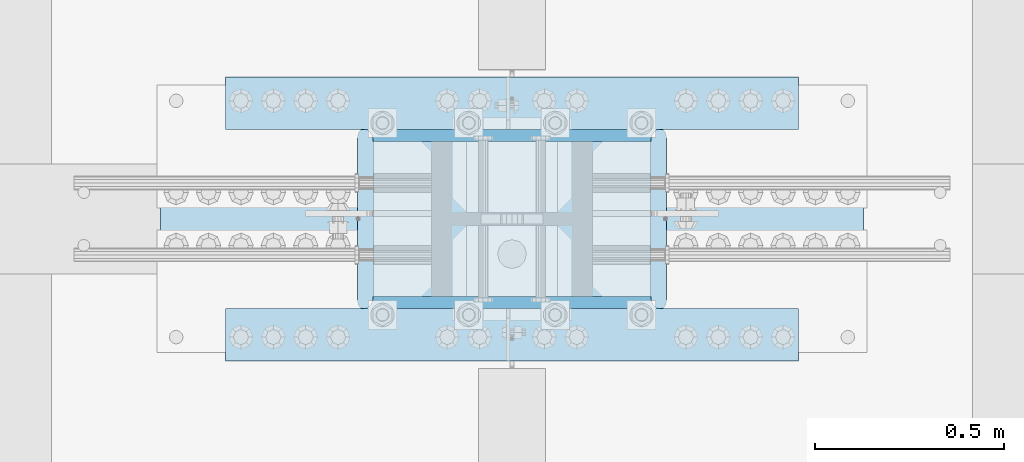
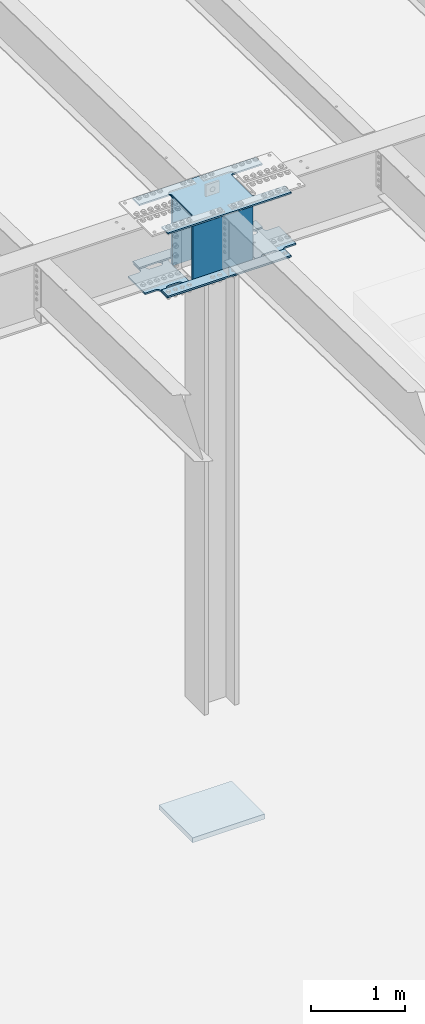
# One storey, part 1410 of 1763: 8 plates, 3 elements without a shape of their own.
"""IFC2X3 building model written with IfcOpenShell, lengths in millimetres."""

from ifc_helpers import new_model, si_unit, frame, origin_with_axes, place, context, subcontext, project, spatial, faceted_brep, material, type_object, element, aggregate, save


model = new_model("IFC2X3")

# Units and contexts
model_context = context("Model", 3, precision=1e-05, world=origin_with_axes())
body_context = subcontext(model_context, "Body", "Model", "MODEL_VIEW")
ifc_project = project(units=[si_unit("LENGTHUNIT", "METRE", prefix="MILLI"), si_unit("AREAUNIT", "SQUARE_METRE"), si_unit("VOLUMEUNIT", "CUBIC_METRE"), si_unit("MASSUNIT", "GRAM", prefix="KILO"), si_unit("TIMEUNIT", "SECOND"), si_unit("PLANEANGLEUNIT", "RADIAN"), si_unit("SOLIDANGLEUNIT", "STERADIAN"), si_unit("THERMODYNAMICTEMPERATUREUNIT", "DEGREE_CELSIUS"), si_unit("LUMINOUSINTENSITYUNIT", "LUMEN")], contexts=[model_context])

# Site, building, storey
site_placement = place(None, origin_with_axes())
site = spatial("IfcSite", under=ifc_project, at=site_placement, CompositionType="ELEMENT")
building_placement = place(site_placement, origin_with_axes())
building = spatial("IfcBuilding", under=site, at=building_placement, Name="Undefined", CompositionType="ELEMENT")
storey_placement = place(building_placement, origin_with_axes())
storey = spatial("IfcBuildingStorey", under=building, at=storey_placement, Name="Undefined", CompositionType="ELEMENT", Elevation=0.0)

# Assembly, plate
assembly_1_placement = place(storey_placement, origin_with_axes())
assembly_1 = element("IfcElementAssembly", 1, at=assembly_1_placement, inside=storey, Name="PLATE", AssemblyPlace="NOTDEFINED", PredefinedType="RIGID_FRAME")
ifc_material_1 = material(Name="STEEL/A572-50")
plate_type_1 = type_object("IfcPlateType", PredefinedType="NOTDEFINED")
plate_1_placement = place(assembly_1_placement, frame((-61638.8822232193, 96.8375244140448, 11057.4961714953), z_axis=(-1.0, 0.0, 0.0), x_axis=(0.0, 1.0, 0.0)))
plate_1 = element("IfcPlate", 2, at=plate_1_placement, type_object=plate_type_1, material=ifc_material_1, Name="PLATE", context=body_context, shape_type="Brep", body=[
    faceted_brep([(177.799939142153, -9.52499999999964, 479.364864346178), (177.799939142153, 9.52499999999964, 479.364864346178), (175.935192487686, 9.52499999999964, 467.591317332008), (175.935192487686, -9.52499999999964, 467.591317332008), (170.523486919264, 9.52499999999964, 456.97024713071), (170.523486919264, -9.52499999999964, 456.97024713071), (162.094557883494, 9.52499999999964, 448.541318094933), (162.094557883494, -9.52499999999964, 448.541318094933), (151.4734876822, 9.52499999999964, 443.1296125265), (151.4734876822, -9.52499999999964, 443.1296125265), (139.699940668032, 9.52499999999964, 441.264865872028), (139.699940668032, -9.52499999999964, 441.264865872028), (127.926386024366, 9.52499999999964, 443.1296125265), (127.926386024366, -9.52499999999964, 443.1296125265), (117.305315823075, 9.52499999999964, 448.541318094925), (117.305315823075, -9.52499999999964, 448.541318094925), (108.876386787306, 9.52499999999964, 456.970247130695), (108.876386787306, -9.52499999999964, 456.970247130695), (103.464681218881, 9.52499999999964, 467.591317331986), (103.464681218881, -9.52499999999964, 467.591317331986), (101.599934564408, 9.52499999999964, 479.364864346149), (101.599934564408, -9.52499999999964, 479.364864346149), (101.599934564408, 9.52499999999964, 600.014873502398), (101.599934564408, -9.52499999999964, 600.014873502398), (103.464681218941, 9.52499999999964, 611.788420516743), (103.464681218941, -9.52499999999964, 611.788420516743), (108.876386787534, 9.52499999999964, 622.409490718164), (108.876386787534, -9.52499999999964, 622.409490718164), (117.305315823547, 9.52499999999964, 630.838419753964), (117.305315823547, -9.52499999999964, 630.838419753964), (127.926386025105, 9.52499999999964, 636.25012532228), (127.926386025105, -9.52499999999964, 636.25012532228), (139.699940668921, 9.52499999999964, 638.114871976519), (139.699940668921, -9.52499999999964, 638.114871976519), (151.473487682847, 9.52499999999964, 636.250125321807), (151.473487682847, -9.52499999999964, 636.250125321807), (162.094557883867, 9.52499999999964, 630.83841975328), (162.094557883867, -9.52499999999964, 630.83841975328), (170.523486919393, 9.52499999999964, 622.409490717546), (170.523486919393, -9.52499999999964, 622.409490717546), (175.935192487652, 9.52499999999964, 611.788420516394), (175.935192487652, -9.52499999999964, 611.788420516394), (177.799939142071, 9.52499999999964, 600.01487350242), (177.799939142071, -9.52499999999964, 600.01487350242), (542.924972534173, -9.52499999999964, 885.855102539062), (542.924972534173, 9.52499999999964, 885.855102539062), (177.800003051751, 9.52499999999964, 885.855102539062), (177.800003051751, -9.52499999999964, 885.855063622585), (542.924972534173, -9.52499999999964, 752.414870449502), (542.924972534173, 9.52499999999964, 752.414870449502), (544.789719188646, -9.52499999999964, 740.641323435339), (544.789719188646, 9.52499999999964, 740.641323435339), (550.20142475707, -9.52499999999964, 730.020253234048), (550.20142475707, 9.52499999999964, 730.020253234048), (558.63035379284, -9.52499999999964, 721.591324198278), (558.63035379284, 9.52499999999964, 721.591324198278), (569.251423994131, -9.52499999999964, 716.179618629852), (569.251423994131, 9.52499999999964, 716.179618629852), (581.024971008294, -9.52499999999964, 714.314871975381), (581.024971008294, 9.52499999999964, 714.314871975381), (720.724975586481, -9.52499999999964, 714.314871975381), (720.724975585938, 9.52499999999964, 714.314871975381), (720.724975585938, -9.52499999999964, 7.27595761418343e-12), (720.724975585938, 9.52499999999964, 7.27595761418343e-12), (619.125, -9.52499999999964, 0.0), (619.125, 9.52499999999964, 0.0), (619.124958978549, -9.52499999999964, 326.964881896973), (619.124958978549, 9.52499999999964, 326.964881896973), (617.260212324076, -9.52499999999964, 338.738428911136), (617.260212324076, 9.52499999999964, 338.738428911136), (611.848506755652, -9.52499999999964, 349.359499112426), (611.848506755652, 9.52499999999964, 349.359499112426), (603.419577719882, -9.52499999999964, 357.788428148197), (603.419577719882, 9.52499999999964, 357.788428148197), (592.798507518591, -9.52499999999964, 363.200133716622), (592.798507518591, 9.52499999999964, 363.200133716622), (581.024960504428, -9.52499999999964, 365.064880371094), (581.024960504428, 9.52499999999964, 365.064880371094), (139.699933038564, -9.52499999999964, 365.064880371094), (139.699933038564, 9.52499999999964, 365.064880371094), (127.9263860244, -9.52499999999964, 363.200133716622), (127.9263860244, 9.52499999999964, 363.200133716622), (117.305315823109, -9.52499999999964, 357.788428148197), (117.305315823109, 9.52499999999964, 357.788428148197), (108.876386787339, -9.52499999999964, 349.359499112426), (108.876386787339, 9.52499999999964, 349.359499112426), (103.464681218915, -9.52499999999964, 338.738428911129), (103.464681218915, 9.52499999999964, 338.738428911129), (101.599934564443, -9.52499999999964, 326.964881896965), (101.599934564443, 9.52499999999964, 326.964881896965), (101.599934564487, -9.52499999999964, 0.0), (101.599934564487, 9.52499999999964, 0.0), (0.0, -9.52500000000146, 0.0), (0.0, 9.52500000000146, 0.0), (-3.68345354218036e-11, -9.52499999999964, 714.314871972194), (-3.68345354218036e-11, 9.52499999999964, 714.314871972194), (139.700004577691, -9.52499999999964, 714.314871972194), (139.700004577691, 9.52499999999964, 714.314871972194), (151.473551591857, -9.52499999999964, 716.179618626666), (151.473551591857, 9.52499999999964, 716.179618626666), (162.094621793151, -9.52499999999964, 721.591324195098), (162.094621793151, 9.52499999999964, 721.591324195098), (170.523550828921, -9.52499999999964, 730.020253230869), (170.523550828921, 9.52499999999964, 730.020253230869), (175.935256397344, -9.52499999999964, 740.641323432166), (175.935256397344, 9.52499999999964, 740.641323432166), (177.800003051812, -9.52499999999964, 752.41487044633), (177.800003051812, 9.52499999999964, 752.41487044633), (617.260212324486, -9.52499999999964, 467.591317332102), (611.848506756063, -9.52499999999964, 456.970247130805), (603.419577720293, -9.52499999999964, 448.541318095035), (592.798507519, -9.52499999999964, 443.129612526602), (581.024960504833, -9.52499999999964, 441.26486587213), (569.251405861195, -9.52499999999964, 443.129612526602), (558.630335659904, -9.52499999999964, 448.541318095027), (550.201406624135, -9.52499999999964, 456.970247130797), (544.78970105571, -9.52499999999964, 467.591317332088), (542.924954401237, -9.52499999999964, 479.364864346251), (542.924954401237, -9.52499999999964, 600.014873502478), (544.789701055769, -9.52499999999964, 611.788420516823), (550.201406624359, -9.52499999999964, 622.409490718237), (558.630335660367, -9.52499999999964, 630.838419754036), (569.25140586192, -9.52499999999964, 636.25012532236), (581.024960505725, -9.52499999999964, 638.114871976599), (592.798507519656, -9.52499999999964, 636.250125321894), (603.419577720682, -9.52499999999964, 630.838419753367), (611.848506756213, -9.52499999999964, 622.409490717633), (617.260212324474, -9.52499999999964, 611.788420516474), (619.124958978893, -9.52499999999964, 600.0148735025), (619.124958978954, -9.52499999999964, 479.364864346273), (611.848506756213, 9.52499999999964, 622.409490717633), (617.260212324474, 9.52499999999964, 611.788420516474), (603.419577720682, 9.52499999999964, 630.838419753367), (592.798507519656, 9.52499999999964, 636.250125321894), (581.024960505725, 9.52499999999964, 638.114871976599), (569.25140586192, 9.52499999999964, 636.25012532236), (558.630335660367, 9.52499999999964, 630.838419754036), (550.201406624359, 9.52499999999964, 622.409490718237), (544.789701055769, 9.52499999999964, 611.788420516823), (542.924954401237, 9.52499999999964, 600.014873502478), (542.924954401237, 9.52499999999964, 479.364864346251), (544.78970105571, 9.52499999999964, 467.591317332088), (550.201406624135, 9.52499999999964, 456.970247130797), (558.630335659904, 9.52499999999964, 448.541318095027), (569.251405861195, 9.52499999999964, 443.129612526602), (581.024960504833, 9.52499999999964, 441.26486587213), (592.798507519, 9.52499999999964, 443.129612526602), (603.419577720293, 9.52499999999964, 448.541318095035), (611.848506756063, 9.52499999999964, 456.970247130805), (617.260212324486, 9.52499999999964, 467.591317332102), (619.124958978954, 9.52499999999964, 479.364864346273), (619.124958978893, 9.52499999999964, 600.0148735025)], [[[0, 1, 2, 3]], [[3, 2, 4, 5]], [[5, 4, 6, 7]], [[7, 6, 8, 9]], [[9, 8, 10, 11]], [[11, 10, 12, 13]], [[13, 12, 14, 15]], [[15, 14, 16, 17]], [[17, 16, 18, 19]], [[19, 18, 20, 21]], [[21, 20, 22, 23]], [[23, 22, 24, 25]], [[25, 24, 26, 27]], [[27, 26, 28, 29]], [[29, 28, 30, 31]], [[31, 30, 32, 33]], [[33, 32, 34, 35]], [[35, 34, 36, 37]], [[37, 36, 38, 39]], [[39, 38, 40, 41]], [[41, 40, 42, 43]], [[43, 42, 1, 0]], [[44, 45, 46, 47]], [[44, 48, 49, 45]], [[50, 51, 49, 48]], [[52, 53, 51, 50]], [[54, 55, 53, 52]], [[56, 57, 55, 54]], [[58, 59, 57, 56]], [[60, 61, 59, 58]], [[62, 63, 61, 60]], [[63, 62, 64, 65]], [[66, 67, 65, 64]], [[68, 69, 67, 66]], [[70, 71, 69, 68]], [[72, 73, 71, 70]], [[74, 75, 73, 72]], [[76, 77, 75, 74]], [[78, 79, 77, 76]], [[80, 81, 79, 78]], [[82, 83, 81, 80]], [[84, 85, 83, 82]], [[86, 87, 85, 84]], [[88, 89, 87, 86]], [[90, 91, 89, 88]], [[92, 93, 91, 90]], [[93, 92, 94, 95]], [[96, 97, 95, 94]], [[98, 99, 97, 96]], [[100, 101, 99, 98]], [[102, 103, 101, 100]], [[104, 105, 103, 102]], [[106, 107, 105, 104]], [[47, 46, 107, 106]], [[104, 102, 100, 98, 96, 94, 92, 90, 88, 86, 84, 82, 80, 78, 76, 74, 72, 70, 68, 66, 64, 62, 60, 58, 56, 54, 52, 50, 48, 44, 47, 106], [3, 5, 7, 9, 11, 13, 15, 17, 19, 21, 23, 25, 27, 29, 31, 33, 35, 37, 39, 41, 43, 0], [108, 109, 110, 111, 112, 113, 114, 115, 116, 117, 118, 119, 120, 121, 122, 123, 124, 125, 126, 127, 128, 129]], [[126, 130, 131, 127]], [[125, 132, 130, 126]], [[124, 133, 132, 125]], [[123, 134, 133, 124]], [[122, 135, 134, 123]], [[121, 136, 135, 122]], [[120, 137, 136, 121]], [[119, 138, 137, 120]], [[118, 139, 138, 119]], [[117, 140, 139, 118]], [[116, 141, 140, 117]], [[115, 142, 141, 116]], [[114, 143, 142, 115]], [[113, 144, 143, 114]], [[112, 145, 144, 113]], [[111, 146, 145, 112]], [[110, 147, 146, 111]], [[109, 148, 147, 110]], [[108, 149, 148, 109]], [[129, 150, 149, 108]], [[128, 151, 150, 129]], [[127, 131, 151, 128]], [[45, 49, 51, 53, 55, 57, 59, 61, 63, 65, 67, 69, 71, 73, 75, 77, 79, 81, 83, 85, 87, 89, 91, 93, 95, 97, 99, 101, 103, 105, 107, 46], [38, 36, 34, 32, 30, 28, 26, 24, 22, 20, 18, 16, 14, 12, 10, 8, 6, 4, 2, 1, 42, 40], [130, 132, 133, 134, 135, 136, 137, 138, 139, 140, 141, 142, 143, 144, 145, 146, 147, 148, 149, 150, 151, 131]]]),
])
aggregate(assembly_1, [plate_1])

assembly_2_placement = place(storey_placement, origin_with_axes())
assembly_2 = element("IfcElementAssembly", 3, at=assembly_2_placement, inside=storey, Name="PLATE", AssemblyPlace="NOTDEFINED", PredefinedType="RIGID_FRAME")
plate_2_placement = place(assembly_2_placement, frame((-61549.9922661248, 817.562475585955, 11057.4961714953), z_axis=(1.0, 0.0, 0.0), x_axis=(0.0, -1.0, 0.0)))
plate_2 = element("IfcPlate", 4, at=plate_2_placement, type_object=plate_type_1, material=ifc_material_1, Name="PLATE", context=body_context, shape_type="Brep", body=[
    faceted_brep([(177.799972534359, -9.52499999999964, 479.429978690481), (177.799972534359, 9.52499999999964, 479.429978690481), (175.935225879886, 9.52499999999964, 467.656431676318), (175.935225879886, -9.52499999999964, 467.656431676318), (170.523520311461, 9.52499999999964, 457.035361475027), (170.523520311461, -9.52499999999964, 457.035361475027), (162.094591275692, 9.52499999999964, 448.606432439257), (162.094591275692, -9.52499999999964, 448.606432439257), (151.473521074401, 9.52499999999964, 443.194726870832), (151.473521074401, -9.52499999999964, 443.194726870832), (139.699974060238, 9.52499999999964, 441.32998021636), (139.699974060238, -9.52499999999964, 441.32998021636), (127.926419416681, 9.52499999999964, 443.194726870832), (127.926419416681, -9.52499999999964, 443.194726870832), (117.30534921539, 9.52499999999964, 448.606432439257), (117.30534921539, -9.52499999999964, 448.606432439257), (108.876420179621, 9.52499999999964, 457.035361475027), (108.876420179621, -9.52499999999964, 457.035361475027), (103.464714611196, 9.52499999999964, 467.656431676318), (103.464714611196, -9.52499999999964, 467.656431676318), (101.599967956723, 9.52499999999964, 479.429978690481), (101.599967956723, -9.52499999999964, 479.429978690481), (101.599967956723, 9.52499999999964, 600.079987847632), (101.599967956723, -9.52499999999964, 600.079987847632), (103.464714611312, 9.52499999999964, 611.853534862152), (103.464714611312, -9.52499999999964, 611.853534862152), (108.876420180062, 9.52499999999964, 622.474605063697), (108.876420180062, -9.52499999999964, 622.474605063697), (117.305349216301, 9.52499999999964, 630.903534099518), (117.305349216301, -9.52499999999964, 630.903534099518), (127.92641941811, 9.52499999999964, 636.315239667747), (127.92641941811, -9.52499999999964, 636.315239667747), (139.699974062116, 9.52499999999964, 638.179986321753), (139.699974062116, -9.52499999999964, 638.179986321753), (151.47352107583, 9.52499999999964, 636.315239666816), (151.47352107583, -9.52499999999964, 636.315239666816), (162.094591276604, 9.52499999999964, 630.903534098194), (162.094591276604, -9.52499999999964, 630.903534098194), (170.523520311904, 9.52499999999964, 622.474605062482), (170.523520311904, -9.52499999999964, 622.474605062482), (175.935225880003, 9.52499999999964, 611.853534861439), (175.935225880003, -9.52499999999964, 611.853534861439), (177.79997253436, 9.52499999999964, 600.079987847632), (177.79997253436, -9.52499999999964, 600.079987847632), (542.924972534183, -9.52499999999964, 885.85498046875), (542.924972534183, 9.52499999999964, 885.85498046875), (177.800003051761, 9.52499999999964, 885.85498046875), (177.800003051761, -9.52499999999964, 885.85501020751), (542.924972534183, -9.52499999999964, 752.479987322513), (542.924972534183, 9.52499999999964, 752.479987322513), (544.789719188656, -9.52499999999964, 740.70644030835), (544.789719188656, 9.52499999999964, 740.70644030835), (550.201424757081, -9.52499999999964, 730.085370107059), (550.201424757081, 9.52499999999964, 730.085370107059), (558.63035379285, -9.52499999999964, 721.656441071289), (558.63035379285, 9.52499999999964, 721.656441071289), (569.251423994141, -9.52499999999964, 716.244735502863), (569.251423994141, 9.52499999999964, 716.244735502863), (581.024971008304, -9.52499999999964, 714.379988848392), (581.024971008304, 9.52499999999964, 714.379988848392), (720.724975585823, -9.52499999999964, 714.379988848392), (720.724975585938, 9.52499999999964, 714.379988848392), (720.724975585938, -9.52499999999964, 7.27595761418343e-12), (720.724975585938, 9.52499999999964, 7.27595761418343e-12), (619.125, -9.52499999999964, 0.0), (619.125, 9.52499999999964, 0.0), (619.125016607424, -9.52499999999964, 327.029975891113), (619.125016607424, 9.52499999999964, 327.029975891113), (617.260269952951, -9.52499999999964, 338.803522905277), (617.260269952951, 9.52499999999964, 338.803522905277), (611.848564384526, -9.52499999999964, 349.424593106567), (611.848564384526, 9.52499999999964, 349.424593106567), (603.419635348757, -9.52499999999964, 357.853522142337), (603.419635348757, 9.52499999999964, 357.853522142337), (592.798565147466, -9.52499999999964, 363.265227710763), (592.798565147466, 9.52499999999964, 363.265227710763), (581.025018133303, -9.52499999999964, 365.129974365234), (581.025018133303, 9.52499999999964, 365.129974365234), (139.699990667474, -9.52499999999964, 365.129974365234), (139.699990667474, 9.52499999999964, 365.129974365234), (127.926443653311, -9.52499999999964, 363.265227710763), (127.926443653311, 9.52499999999964, 363.265227710763), (117.30537345202, -9.52499999999964, 357.853522142337), (117.30537345202, 9.52499999999964, 357.853522142337), (108.876444416251, -9.52499999999964, 349.424593106567), (108.876444416251, 9.52499999999964, 349.424593106567), (103.464738847827, -9.52499999999964, 338.803522905277), (103.464738847827, 9.52499999999964, 338.803522905277), (101.599992193353, -9.52499999999964, 327.029975891113), (101.599992193353, 9.52499999999964, 327.029975891113), (101.599992193361, -9.52499999999964, 0.0), (101.599992193361, 9.52499999999964, 0.0), (0.0, -9.52500000000146, 0.0), (0.0, 9.52500000000146, 0.0), (-1.47792889038101e-12, -9.52499999999964, 714.379988845205), (-1.47792889038101e-12, 9.52499999999964, 714.379988845205), (139.70000457776, -9.52499999999964, 714.379988845205), (139.70000457776, 9.52499999999964, 714.379988845205), (151.47355159193, -9.52499999999964, 716.244735499677), (151.47355159193, 9.52499999999964, 716.244735499677), (162.094621793225, -9.52499999999964, 721.656441068109), (162.094621793225, 9.52499999999964, 721.656441068109), (170.523550828996, -9.52499999999964, 730.085370103887), (170.523550828996, 9.52499999999964, 730.085370103887), (175.935256397417, -9.52499999999964, 740.706440305192), (175.935256397417, 9.52499999999964, 740.706440305192), (177.800003051881, -9.52499999999964, 752.479987319362), (177.800003051881, 9.52499999999964, 752.479987319362), (617.260225879886, -9.52499999999964, 467.656431676682), (611.848520311461, -9.52499999999964, 457.035361475391), (603.419591275692, -9.52499999999964, 448.606432439621), (592.798521074401, -9.52499999999964, 443.194726871196), (581.024974060238, -9.52499999999964, 441.329980216724), (569.251419416681, -9.52499999999964, 443.194726871196), (558.63034921539, -9.52499999999964, 448.606432439621), (550.201420179621, -9.52499999999964, 457.035361475391), (544.789714611196, -9.52499999999964, 467.656431676682), (542.924967956723, -9.52499999999964, 479.429978690845), (542.924967956723, -9.52499999999964, 600.079987847996), (544.789714611312, -9.52499999999964, 611.853534862523), (550.201420180063, -9.52499999999964, 622.474605064061), (558.630349216303, -9.52499999999964, 630.903534099889), (569.251419418112, -9.52499999999964, 636.315239668111), (581.02497406212, -9.52499999999964, 638.179986322117), (592.798521075833, -9.52499999999964, 636.315239667179), (603.419591276606, -9.52499999999964, 630.903534098557), (611.848520311905, -9.52499999999964, 622.474605062846), (617.260225880003, -9.52499999999964, 611.853534861802), (619.12497253436, -9.52499999999964, 600.079987847996), (619.124972534359, -9.52499999999964, 479.429978690845), (611.848520311905, 9.52499999999964, 622.474605062846), (617.260225880003, 9.52499999999964, 611.853534861802), (603.419591276606, 9.52499999999964, 630.903534098557), (592.798521075833, 9.52499999999964, 636.315239667179), (581.02497406212, 9.52499999999964, 638.179986322117), (569.251419418112, 9.52499999999964, 636.315239668111), (558.630349216303, 9.52499999999964, 630.903534099889), (550.201420180063, 9.52499999999964, 622.474605064061), (544.789714611312, 9.52499999999964, 611.853534862523), (542.924967956723, 9.52499999999964, 600.079987847996), (542.924967956723, 9.52499999999964, 479.429978690845), (544.789714611196, 9.52499999999964, 467.656431676682), (550.201420179621, 9.52499999999964, 457.035361475391), (558.63034921539, 9.52499999999964, 448.606432439621), (569.251419416681, 9.52499999999964, 443.194726871196), (581.024974060238, 9.52499999999964, 441.329980216724), (592.798521074401, 9.52499999999964, 443.194726871196), (603.419591275692, 9.52499999999964, 448.606432439621), (611.848520311461, 9.52499999999964, 457.035361475391), (617.260225879886, 9.52499999999964, 467.656431676682), (619.124972534359, 9.52499999999964, 479.429978690845), (619.12497253436, 9.52499999999964, 600.079987847996)], [[[0, 1, 2, 3]], [[3, 2, 4, 5]], [[5, 4, 6, 7]], [[7, 6, 8, 9]], [[9, 8, 10, 11]], [[11, 10, 12, 13]], [[13, 12, 14, 15]], [[15, 14, 16, 17]], [[17, 16, 18, 19]], [[19, 18, 20, 21]], [[21, 20, 22, 23]], [[23, 22, 24, 25]], [[25, 24, 26, 27]], [[27, 26, 28, 29]], [[29, 28, 30, 31]], [[31, 30, 32, 33]], [[33, 32, 34, 35]], [[35, 34, 36, 37]], [[37, 36, 38, 39]], [[39, 38, 40, 41]], [[41, 40, 42, 43]], [[43, 42, 1, 0]], [[44, 45, 46, 47]], [[44, 48, 49, 45]], [[50, 51, 49, 48]], [[52, 53, 51, 50]], [[54, 55, 53, 52]], [[56, 57, 55, 54]], [[58, 59, 57, 56]], [[60, 61, 59, 58]], [[62, 63, 61, 60]], [[63, 62, 64, 65]], [[66, 67, 65, 64]], [[68, 69, 67, 66]], [[70, 71, 69, 68]], [[72, 73, 71, 70]], [[74, 75, 73, 72]], [[76, 77, 75, 74]], [[78, 79, 77, 76]], [[80, 81, 79, 78]], [[82, 83, 81, 80]], [[84, 85, 83, 82]], [[86, 87, 85, 84]], [[88, 89, 87, 86]], [[90, 91, 89, 88]], [[92, 93, 91, 90]], [[93, 92, 94, 95]], [[96, 97, 95, 94]], [[98, 99, 97, 96]], [[100, 101, 99, 98]], [[102, 103, 101, 100]], [[104, 105, 103, 102]], [[106, 107, 105, 104]], [[47, 46, 107, 106]], [[104, 102, 100, 98, 96, 94, 92, 90, 88, 86, 84, 82, 80, 78, 76, 74, 72, 70, 68, 66, 64, 62, 60, 58, 56, 54, 52, 50, 48, 44, 47, 106], [3, 5, 7, 9, 11, 13, 15, 17, 19, 21, 23, 25, 27, 29, 31, 33, 35, 37, 39, 41, 43, 0], [108, 109, 110, 111, 112, 113, 114, 115, 116, 117, 118, 119, 120, 121, 122, 123, 124, 125, 126, 127, 128, 129]], [[126, 130, 131, 127]], [[125, 132, 130, 126]], [[124, 133, 132, 125]], [[123, 134, 133, 124]], [[122, 135, 134, 123]], [[121, 136, 135, 122]], [[120, 137, 136, 121]], [[119, 138, 137, 120]], [[118, 139, 138, 119]], [[117, 140, 139, 118]], [[116, 141, 140, 117]], [[115, 142, 141, 116]], [[114, 143, 142, 115]], [[113, 144, 143, 114]], [[112, 145, 144, 113]], [[111, 146, 145, 112]], [[110, 147, 146, 111]], [[109, 148, 147, 110]], [[108, 149, 148, 109]], [[129, 150, 149, 108]], [[128, 151, 150, 129]], [[127, 131, 151, 128]], [[45, 49, 51, 53, 55, 57, 59, 61, 63, 65, 67, 69, 71, 73, 75, 77, 79, 81, 83, 85, 87, 89, 91, 93, 95, 97, 99, 101, 103, 105, 107, 46], [38, 36, 34, 32, 30, 28, 26, 24, 22, 20, 18, 16, 14, 12, 10, 8, 6, 4, 2, 1, 42, 40], [130, 132, 133, 134, 135, 136, 137, 138, 139, 140, 141, 142, 143, 144, 145, 146, 147, 148, 149, 150, 151, 131]]]),
])
aggregate(assembly_2, [plate_2])

# Assembly, plates
assembly_3_placement = place(storey_placement, origin_with_axes())
assembly_3 = element("IfcElementAssembly", 5, at=assembly_3_placement, inside=storey, Name="COLUMN", AssemblyPlace="NOTDEFINED", PredefinedType="RIGID_FRAME")
plate_type_2 = type_object("IfcPlateType", PredefinedType="NOTDEFINED")
plate_3_placement = place(assembly_3_placement, frame((-60835.5972448818, 833.437499804274, 11076.5461722448), z_axis=(-1.0, 0.0, 0.0), x_axis=(0.0, -1.0, 0.0)))
plate_3 = element("IfcPlate", 6, at=plate_3_placement, type_object=plate_type_2, material=ifc_material_1, Name="PLATE", context=body_context, shape_type="Brep", body=[
    faceted_brep([(0.0, -9.52500000000146, 0.0), (6.34622601864976e-05, -9.52500000067448, 1517.59985351565), (6.34622598454371e-05, 9.52499999932479, 1517.59985351559), (0.0, 9.52500000000146, 0.0), (139.700057983352, -9.52500000073633, 1517.59985351522), (139.700057983352, 9.52499999926295, 1517.59985351515), (139.700012207031, -9.52499999993779, -4.65661287307739e-10), (139.700012207031, 9.52500000006148, -3.92901711165905e-10)], [[[0, 1, 2, 3]], [[1, 4, 5, 2]], [[4, 6, 7, 5]], [[6, 0, 3, 7]], [[5, 7, 3, 2]], [[6, 4, 1, 0]]]),
])
plate_4_placement = place(assembly_3_placement, frame((-60835.5972448818, 80.9624876163431, 11076.5461722448), z_axis=(-1.0, 0.0, 0.0), x_axis=(0.0, 1.0, 0.0)))
plate_4 = element("IfcPlate", 7, at=plate_4_placement, type_object=plate_type_2, material=ifc_material_1, Name="PLATE", context=body_context, shape_type="Brep", body=[
    faceted_brep([(0.0, -9.52500000000146, 0.0), (6.34622601864976e-05, -9.52500000067448, 1517.59985351565), (6.34622598454371e-05, 9.52499999932479, 1517.59985351559), (0.0, 9.52500000000146, 0.0), (139.700057983352, -9.52500000073633, 1517.59985351522), (139.700057983352, 9.52499999926295, 1517.59985351515), (139.700012207031, -9.52499999993779, -4.65661287307739e-10), (139.700012207031, 9.52500000006148, -3.92901711165905e-10)], [[[0, 1, 2, 3]], [[1, 4, 5, 2]], [[4, 6, 7, 5]], [[6, 0, 3, 7]], [[5, 7, 3, 2]], [[6, 4, 1, 0]]]),
])
plate_type_3 = type_object("IfcPlateType", PredefinedType="NOTDEFINED")
plate_5_placement = place(assembly_3_placement, frame((-60835.5922083174, 80.9625246742528, 11898.8711718243), z_axis=(-1.0, 0.0, 0.0), x_axis=(0.0, 1.0, 0.0)))
plate_5 = element("IfcPlate", 8, at=plate_5_placement, type_object=plate_type_3, material=ifc_material_1, Name="PLATE", context=body_context, shape_type="Brep", body=[
    faceted_brep([(139.699957294732, -9.52499999993597, 1517.60485839844), (139.699979928451, -9.52499999993597, 1152.54507526163), (139.699979947509, 9.5250000000633, 1152.54507529975), (139.69995731379, 9.5250000000633, 1517.60485839844), (141.633440161372, -9.52499999993597, 1142.82491686424), (141.633440180431, 9.52500000006512, 1142.82491690235), (147.139467893951, -9.52499999993233, 1134.58456454465), (147.139467913009, 9.52500000006694, 1134.58456458277), (155.379820409339, -9.5249999999287, 1129.07853710512), (155.379820428397, 9.52500000007058, 1129.07853714324), (165.09997887549, -9.52499999992506, 1127.14507721786), (165.099978894548, 9.52500000007421, 1127.14507725598), (587.374991845394, -9.5249999997377, 1127.14506605364), (587.374991864452, 9.52500000026157, 1127.14506609176), (597.095151451441, -9.52499999973406, 1129.07852585674), (597.0951514705, 9.52500000026703, 1129.07852589486), (605.335504808676, -9.52499999973043, 1134.58455401914), (605.335504827735, 9.52500000027067, 1134.58455405726), (610.841532678005, -9.52499999972679, 1142.82490757219), (610.841532697064, 9.52500000027248, 1142.82490761031), (612.774992135416, -9.52499999972679, 1152.545067247), (612.774992154474, 9.52500000027248, 1152.54506728511), (612.774969500707, -9.52499999972679, 1517.6049042493), (612.774969519765, 9.52500000027248, 1517.60485839844), (0.0, -9.52500000000146, 0.0), (-2.67627764998224e-05, -9.52499999999964, 1517.60485839844), (-2.67627765992984e-05, 9.52499999999964, 1517.60485839844), (0.0, 9.52500000000146, 0.0), (139.700012207031, -9.52499999993779, -4.65661287307739e-10), (139.700012207031, 9.52500000006148, -3.92901711165905e-10), (139.699983713202, 9.5250000000633, 365.145156737148), (139.699983694143, -9.52499999993597, 365.145156870487), (141.633443616699, 9.52500000006512, 374.865315761628), (141.633443597641, -9.52499999993597, 374.865315894967), (147.139471467098, 9.52500000006694, 383.105668664888), (147.139471448039, -9.52499999993233, 383.105668798227), (155.379824436441, 9.52500000007058, 388.611696416381), (155.379824417383, -9.5249999999287, 388.61169654972), (165.099983484133, 9.52500000007421, 390.54515620321), (165.099983465075, -9.52499999992506, 390.54515633655), (587.374996453021, 9.52500000026157, 390.545153668434), (587.374996433962, -9.5249999997377, 390.545153801773), (597.095155477494, 9.52500000026703, 388.611693764913), (597.095155458435, -9.52499999973406, 388.61169389826), (605.335508380755, 9.52500000027067, 383.105665914518), (605.335508361697, -9.52499999973043, 383.105666047857), (610.841536132274, 9.52500000027248, 374.865312945185), (610.841536113216, -9.52499999972679, 374.865313078524), (612.77499591915, 9.52500000027248, 365.145153897509), (612.774995900091, -9.52499999972679, 365.145154030848), (612.774993729339, 9.52500000027248, 0.0), (612.774993710281, -9.52499999972679, 0.0), (752.474975585938, 9.52500000033433, 0.0), (752.474975585938, -9.52499999966494, 0.0), (752.474975585938, -9.52499999966494, 1517.60485839844), (752.474975585938, 9.52500000033433, 1517.60485839844)], [[[0, 1, 2, 3]], [[4, 5, 2, 1]], [[6, 7, 5, 4]], [[8, 9, 7, 6]], [[10, 11, 9, 8]], [[12, 13, 11, 10]], [[14, 15, 13, 12]], [[16, 17, 15, 14]], [[18, 19, 17, 16]], [[20, 21, 19, 18]], [[22, 23, 21, 20]], [[24, 25, 26, 27]], [[28, 24, 27, 29]], [[28, 29, 30, 31]], [[31, 30, 32, 33]], [[33, 32, 34, 35]], [[35, 34, 36, 37]], [[37, 36, 38, 39]], [[39, 38, 40, 41]], [[41, 40, 42, 43]], [[43, 42, 44, 45]], [[45, 44, 46, 47]], [[47, 46, 48, 49]], [[49, 48, 50, 51]], [[52, 53, 51, 50]], [[54, 53, 52, 55]], [[18, 16, 14, 12, 10, 8, 6, 4, 1, 0, 25, 24, 28, 31, 33, 35, 37, 39, 41, 43, 45, 47, 49, 51, 53, 54, 22, 20]], [[26, 25, 0, 3]], [[55, 52, 50, 48, 46, 44, 42, 40, 38, 36, 34, 32, 30, 29, 27, 26, 3, 2, 5, 7, 9, 11, 13, 15, 17, 19, 21, 23]], [[54, 55, 23, 22]]]),
])
plate_type_4 = type_object("IfcPlateType", PredefinedType="NOTDEFINED")
plate_6_placement = place(assembly_3_placement, frame((-61962.7372736986, 677.862500000006, 11889.3461712145), z_axis=(1.0, 0.0, 0.0), x_axis=(0.0, 0.0, -1.0)))
plate_6 = element("IfcPlate", 9, at=plate_6_placement, type_object=plate_type_4, material=ifc_material_1, Name="PLATE", context=body_context, shape_type="Brep", body=[
    faceted_brep([(0.0, -15.875, 0.0), (1.12581510620657e-05, -15.875, 736.599975585945), (1.12581346911611e-05, 15.875, 736.599975585945), (0.0, 15.875, 0.0), (898.524963379368, -15.8750000000356, 736.599914553502), (898.52496337935, 15.8749999999644, 736.599914553502), (898.524963378915, -15.8750000000357, 3.28873284161091e-09), (898.524963378899, 15.8749999999643, 3.28873284161091e-09)], [[[0, 1, 2, 3]], [[1, 4, 5, 2]], [[4, 6, 7, 5]], [[6, 0, 3, 7]], [[5, 7, 3, 2]], [[6, 4, 1, 0]]]),
])
plate_7_placement = place(assembly_3_placement, frame((-61962.7372736986, 236.537500000006, 11889.3461714361), z_axis=(1.0, 0.0, 0.0), x_axis=(0.0, 0.0, -1.0)))
plate_7 = element("IfcPlate", 10, at=plate_7_placement, type_object=plate_type_4, material=ifc_material_1, Name="PLATE", context=body_context, shape_type="Brep", body=[
    faceted_brep([(0.0, -15.875, 0.0), (1.12581510620657e-05, -15.875, 736.599975585945), (1.12581346911611e-05, 15.875, 736.599975585945), (0.0, 15.875, 0.0), (898.524963379368, -15.8750000000356, 736.599914553502), (898.52496337935, 15.8749999999644, 736.599914553502), (898.524963378915, -15.8750000000357, 3.28873284161091e-09), (898.524963378899, 15.8749999999643, 3.28873284161091e-09)], [[[0, 1, 2, 3]], [[1, 4, 5, 2]], [[4, 6, 7, 5]], [[6, 0, 3, 7]], [[5, 7, 3, 2]], [[6, 4, 1, 0]]]),
])
ifc_material_2 = material(Name="STEEL/A572-GR.50")
plate_type_5 = type_object("IfcPlateType", PredefinedType="NOTDEFINED")
plate_8_placement = place(assembly_3_placement, frame((-62038.9372736986, 101.600000000006, 3879.85), z_axis=(0.0, 1.0, 0.0), x_axis=(1.0, 0.0, 0.0)))
plate_8 = element("IfcPlate", 11, at=plate_8_placement, type_object=plate_type_5, material=ifc_material_2, Name="PLATE", context=body_context, shape_type="Brep", body=[
    faceted_brep([(-4.54747350886464e-13, -31.7499999999964, 0.0), (0.0, -31.75, 711.200012207031), (0.0, 31.75, 711.200012207031), (-5.91171556152403e-12, 31.7499999999891, 0.0), (889.0, -31.75, 711.200012207031), (889.0, 31.75, 711.200012207031), (889.0, -31.75, 0.0), (889.0, 31.75, 0.0)], [[[0, 1, 2, 3]], [[1, 4, 5, 2]], [[4, 6, 7, 5]], [[6, 0, 3, 7]], [[5, 7, 3, 2]], [[6, 4, 1, 0]]]),
])
aggregate(assembly_3, [plate_3, plate_4, plate_5, plate_6, plate_7, plate_8])

save(model, "model.ifc")
